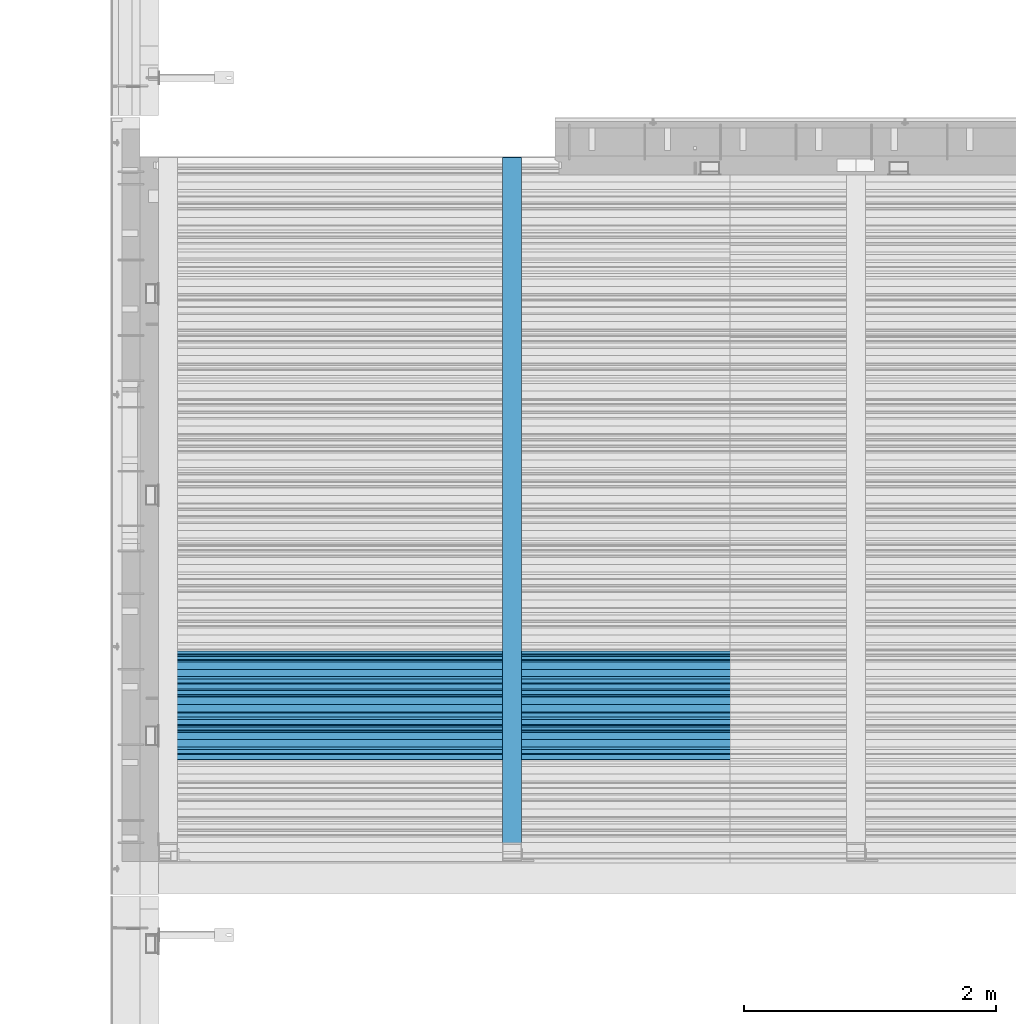
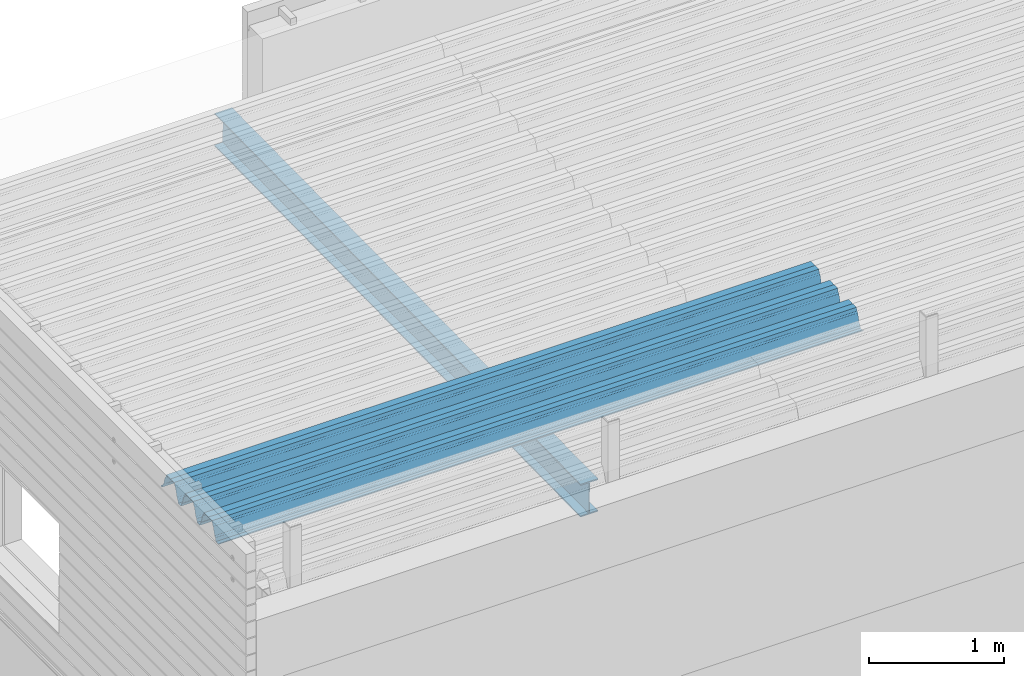
# One storey, part 25 of 153: 2 beams, 2 elements without a shape of their own.
"""IFC2X3 building model written with IfcOpenShell, lengths in millimetres."""

import ifcopenshell
import ifcopenshell.guid

model = None  # the IFC model being written
_history = None  # IfcOwnerHistory: only IFC2X3 demands one
_inside = {}  # id of a spatial element -> (the spatial element, [elements in it])
_under = {}  # id of a project, library or spatial element -> (it, [spatial elements below it])
_declared = {}  # id of a project -> (the project, [libraries it declares])
_typed = {}  # id of a type object -> (the type object, [elements of that type])
_made_of = {}  # id of a material, layer set ... -> (it, [elements and type objects made of it])


def new_model(schema):
    """Start an empty IFC model of exactly this schema.

    Asked for "IFC4X3", IfcOpenShell would pick the latest addendum, in which some entities
    have other attributes; the version numbers below select the first issue.
    IFC2X3 requires an IfcOwnerHistory on every rooted entity: one is made here for all.
    """
    global model, _history
    if schema == "IFC4X3":
        model = ifcopenshell.file(schema_version=(4, 3, 0, 0))
    else:
        model = ifcopenshell.file(schema=schema)
    _inside.clear()
    _under.clear()
    _declared.clear()
    _typed.clear()
    _made_of.clear()
    _history = None
    if model.schema == "IFC2X3":
        org = make("IfcOrganization", Name="unknown")
        user = make(
            "IfcPersonAndOrganization",
            ThePerson=make("IfcPerson", FamilyName="unknown"),
            TheOrganization=org,
        )
        app = make(
            "IfcApplication",
            ApplicationDeveloper=org,
            Version="unknown",
            ApplicationFullName="unknown",
            ApplicationIdentifier="unknown",
        )
        _history = make(
            "IfcOwnerHistory",
            OwningUser=user,
            OwningApplication=app,
            ChangeAction="ADDED",
            CreationDate=0,
        )
    return model


def make(cls, **values):
    """One entity of the class cls with the attributes given. An attribute that is None is left unset."""
    return model.create_entity(
        cls, **{name: value for name, value in values.items() if value is not None}
    )


def rooted(cls, **values):
    """An entity with a GlobalId (a new one), such as an element, a storey or a relation."""
    return make(cls, GlobalId=ifcopenshell.guid.new(), OwnerHistory=_history, **values)


def si_unit(unit_type, name, prefix=None):
    """IfcSIUnit, for example si_unit("LENGTHUNIT", "METRE", prefix="MILLI")."""
    return make("IfcSIUnit", UnitType=unit_type, Prefix=prefix, Name=name)


def assignment(units):
    """IfcUnitAssignment: the units of a project."""
    return None if units is None else make("IfcUnitAssignment", Units=units)


def point(xyz):
    """IfcCartesianPoint."""
    return None if xyz is None else make("IfcCartesianPoint", Coordinates=xyz)


def direction(xyz):
    """IfcDirection."""
    return None if xyz is None else make("IfcDirection", DirectionRatios=xyz)


def frame(location, z_axis=None, x_axis=None):
    """IfcAxis2Placement3D, a coordinate frame: its origin and axes. An axis left out is left unset."""
    return make(
        "IfcAxis2Placement3D",
        Location=point(location),
        Axis=direction(z_axis),
        RefDirection=direction(x_axis),
    )


def origin_with_axes():
    """The frame at (0, 0, 0) with the z axis (0, 0, 1) and the x axis (1, 0, 0) written out."""
    return frame((0.0, 0.0, 0.0), z_axis=(0.0, 0.0, 1.0), x_axis=(1.0, 0.0, 0.0))


def place(relative_to, where):
    """IfcLocalPlacement: puts the frame where relative to a parent placement (None: the world)."""
    return make(
        "IfcLocalPlacement", PlacementRelTo=relative_to, RelativePlacement=where
    )


def context(
    kind, dimensions, precision=None, world=None, true_north=None, identifier=None
):
    """IfcGeometricRepresentationContext, for example the 3D "Model" context."""
    return make(
        "IfcGeometricRepresentationContext",
        ContextIdentifier=identifier,
        ContextType=kind,
        CoordinateSpaceDimension=dimensions,
        Precision=precision,
        WorldCoordinateSystem=world,
        TrueNorth=true_north,
    )


def subcontext(parent, identifier, kind, view, scale=None):
    """IfcGeometricRepresentationSubContext, for example "Body" below "Model"."""
    return make(
        "IfcGeometricRepresentationSubContext",
        ContextIdentifier=identifier,
        ContextType=kind,
        ParentContext=parent,
        TargetScale=scale,
        TargetView=view,
    )


def project(units=None, contexts=None):
    """IfcProject with its units and contexts."""
    return rooted(
        "IfcProject",
        Name="project",
        RepresentationContexts=contexts,
        UnitsInContext=assignment(units),
    )


def spatial(cls, under=None, at=None, **own):
    """A site, building, storey or space (cls), placed at a placement, below another one or the project."""
    s = rooted(cls, ObjectPlacement=at, **own)
    if under is not None:
        _under.setdefault(under.id(), (under, []))[1].append(s)
    return s


def faces_of(points, faces, orient=None, outer=None):
    """IfcFace entities. A face is a list of loops; a loop is a list of indices into points, from 0.

    orient and outer hold one flag for each loop. By default every Orientation is true, the
    first loop of a face is its IfcFaceOuterBound and the others are IfcFaceBound.
    """
    made = []
    for i, loops in enumerate(faces):
        bounds = []
        for j, loop in enumerate(loops):
            is_outer = j == 0 if outer is None else outer[i][j]
            bounds.append(
                make(
                    "IfcFaceOuterBound" if is_outer else "IfcFaceBound",
                    Bound=make("IfcPolyLoop", Polygon=[points[k] for k in loop]),
                    Orientation=True if orient is None else orient[i][j],
                )
            )
        made.append(make("IfcFace", Bounds=bounds))
    return made


def faceted_brep(points, faces, orient=None, outer=None, voids=None):
    """IfcFacetedBrep: a solid bounded by flat faces; with voids (closed shells), ...WithVoids."""
    shared = [point(p) for p in points]
    hull = make("IfcClosedShell", CfsFaces=faces_of(shared, faces, orient, outer))
    if voids is None:
        return make("IfcFacetedBrep", Outer=hull)
    return make(
        "IfcFacetedBrepWithVoids",
        Outer=hull,
        Voids=[
            make(cls, CfsFaces=faces_of(shared, fs, o, b)) for cls, fs, o, b in voids
        ],
    )


def shape(context_of_items, identifier, shape_type, items):
    """IfcShapeRepresentation: the items that make up one representation, for example the "Body"."""
    return make(
        "IfcShapeRepresentation",
        ContextOfItems=context_of_items,
        RepresentationIdentifier=identifier,
        RepresentationType=shape_type,
        Items=items,
    )


def material(Name=None, Category=None):
    """IfcMaterial."""
    return make("IfcMaterial", Name=Name, Category=Category)


def made_of(thing, what):
    """Note that an element or type object is made of a material, layer set ...; save() writes the relation."""
    if what is not None:
        _made_of.setdefault(what.id(), (what, []))[1].append(thing)
    return thing


def type_object(cls, material=None, **own):
    """A type object (cls), such as IfcWallType, which elements share."""
    return made_of(rooted(cls, **own), material)


def element(
    cls,
    number,
    at=None,
    inside=None,
    cuts=None,
    type_object=None,
    material=None,
    context=None,
    identifier="Body",
    shape_type=None,
    held_by="IfcProductDefinitionShape",
    body=None,
    shapes=None,
    **own,
):
    """One element of the class cls, such as IfcWall. Its Tag is "e" and its number.

    at: its placement. inside: the storey or other place that contains it. cuts: it is an
    opening in that element (IfcRelVoidsElement). A single representation is given by context,
    identifier, shape_type and body (its items); several are given by shapes. held_by: the class
    of the entity that holds the representations. save() writes the other relations.
    """
    e = rooted(cls, Tag="e%d" % number, ObjectPlacement=at, **own)
    if body is not None:
        shapes = [shape(context, identifier, shape_type, body)]
    if shapes is not None:
        e.Representation = make(held_by, Representations=shapes)
    if inside is not None:
        _inside.setdefault(inside.id(), (inside, []))[1].append(e)
    if cuts is not None:
        rooted(
            "IfcRelVoidsElement", RelatingBuildingElement=cuts, RelatedOpeningElement=e
        )
    if type_object is not None:
        _typed.setdefault(type_object.id(), (type_object, []))[1].append(e)
    return made_of(e, material)


def aggregate(whole, parts):
    """IfcRelAggregates: a whole, such as a stair, and the parts it consists of."""
    return rooted("IfcRelAggregates", RelatingObject=whole, RelatedObjects=parts)


def save(model, path):
    """Write the relations noted so far, then the file.

    IfcRelAggregates (storeys below a building ...), IfcRelContainedInSpatialStructure (elements
    in a storey), IfcRelDefinesByType, IfcRelAssociatesMaterial and IfcRelDeclares: one each for
    every whole, place, type object, material and project.
    """
    for whole, parts in _under.values():
        aggregate(whole, parts)
    for where, things in _inside.values():
        rooted(
            "IfcRelContainedInSpatialStructure",
            RelatedElements=things,
            RelatingStructure=where,
        )
    for kind, things in _typed.values():
        rooted("IfcRelDefinesByType", RelatedObjects=things, RelatingType=kind)
    for what, things in _made_of.values():
        rooted("IfcRelAssociatesMaterial", RelatedObjects=things, RelatingMaterial=what)
    for by, libraries in _declared.values():
        rooted("IfcRelDeclares", RelatingContext=by, RelatedDefinitions=libraries)
    model.write(path)


model = new_model("IFC2X3")

# Units and contexts
model_context = context("Model", 3, precision=1e-05, world=origin_with_axes())
body_context = subcontext(model_context, "Body", "Model", "MODEL_VIEW")
ifc_project = project(units=[si_unit("LENGTHUNIT", "METRE", prefix="MILLI"), si_unit("AREAUNIT", "SQUARE_METRE"), si_unit("VOLUMEUNIT", "CUBIC_METRE"), si_unit("MASSUNIT", "GRAM", prefix="KILO"), si_unit("TIMEUNIT", "SECOND"), si_unit("PLANEANGLEUNIT", "RADIAN"), si_unit("SOLIDANGLEUNIT", "STERADIAN"), si_unit("THERMODYNAMICTEMPERATUREUNIT", "DEGREE_CELSIUS"), si_unit("LUMINOUSINTENSITYUNIT", "LUMEN")], contexts=[model_context])

# Site, building, storey
site_placement = place(None, origin_with_axes())
site = spatial("IfcSite", under=ifc_project, at=site_placement, CompositionType="ELEMENT")
building_placement = place(site_placement, origin_with_axes())
building = spatial("IfcBuilding", under=site, at=building_placement, CompositionType="ELEMENT")
storey_placement = place(building_placement, origin_with_axes())
storey = spatial("IfcBuildingStorey", under=building, at=storey_placement, Name="8", CompositionType="ELEMENT", Elevation=0.0)

# Assembly, beam
assembly_1_placement = place(storey_placement, origin_with_axes())
assembly_1 = element("IfcElementAssembly", 1, at=assembly_1_placement, inside=storey, Name="Steel Assembly", AssemblyPlace="NOTDEFINED", PredefinedType="RIGID_FRAME")
ifc_material = material(Name="STEEL/S355J2")
beam_type_1 = type_object("IfcBeamType", Name="IPE300", PredefinedType="NOTDEFINED")
beam_1_placement = place(assembly_1_placement, frame((10805.0, 15128.0908589797, 105518.668698055), z_axis=(0.0, -0.0124990270013869, 0.999921884110963), x_axis=(0.0, 0.999921884110963, 0.0124990270013883)))
beam_1 = element("IfcBeam", 2, at=beam_1_placement, type_object=beam_type_1, material=ifc_material, ObjectType="IPE300", context=body_context, shape_type="Brep", body=[
    faceted_brep([(3.63797880709171e-12, 75.0, -149.999999999985), (0.0, 75.0, -139.300000189993), (5440.87494889885, 75.0, -139.300000189993), (5440.87494889886, 75.0, -150.0), (0.0, 3.5499999525, -139.300000189993), (5440.87494889885, 3.5499999525, -139.300000189993), (0.0, 3.5499999525, 139.300000190022), (5440.87494889885, 3.5499999525, 139.300000190022), (0.0, 75.0, 139.300000190022), (5440.87494889885, 75.0, 139.300000190022), (3.63797880709171e-12, 75.0, 150.0), (5440.87494889885, 75.0, 150.0), (3.63797880709171e-12, -75.0, 150.0), (5440.87494889885, -75.0, 150.0), (0.0, -75.0, 139.300000190022), (5440.87494889885, -75.0, 139.300000190022), (0.0, -3.5499999525, 139.300000190022), (5440.87494889885, -3.5499999525, 139.300000190022), (0.0, -3.5499999525, -139.300000189993), (5440.87494889885, -3.5499999525, -139.300000189993), (0.0, -75.0, -139.300000189993), (5440.87494889885, -75.0, -139.300000189993), (3.63797880709171e-12, -75.0, -149.999999999985), (5440.87494889886, -75.0, -150.0)], [[[0, 1, 2, 3]], [[1, 4, 5, 2]], [[4, 6, 7, 5]], [[6, 8, 9, 7]], [[8, 10, 11, 9]], [[10, 12, 13, 11]], [[12, 14, 15, 13]], [[14, 16, 17, 15]], [[16, 18, 19, 17]], [[18, 20, 21, 19]], [[20, 22, 23, 21]], [[22, 0, 3, 23]], [[5, 7, 9, 11, 13, 15, 17, 19, 21, 23, 3, 2]], [[22, 20, 18, 16, 14, 12, 10, 8, 6, 4, 1, 0]]]),
])
aggregate(assembly_1, [beam_1])

assembly_2_placement = place(storey_placement, origin_with_axes())
assembly_2 = element("IfcElementAssembly", 3, at=assembly_2_placement, inside=storey, Name="Steel Assembly", AssemblyPlace="NOTDEFINED", PredefinedType="RIGID_FRAME")
beam_type_2 = type_object("IfcBeamType", Name="W", PredefinedType="NOTDEFINED")
beam_2_placement = place(assembly_2_placement, frame((13534.9999999929, 16215.1442180382, 105760.274680782), z_axis=(0.0, -0.0124990270013869, 0.999921884110963), x_axis=(-1.0, 3.00000001838171e-08, 0.0)))
beam_2 = element("IfcBeam", 4, at=beam_2_placement, type_object=beam_type_2, material=ifc_material, ObjectType="W", context=body_context, shape_type="Brep", body=[
    faceted_brep([(0.0, -412.839996337891, -77.0100021362159), (0.0, -409.160003662109, -77.0100021362014), (5530.0, -409.160003662109, -77.0100021362014), (5530.0, -412.839996337891, -77.0100021362159), (0.0, -408.070007324222, -73.4800033569045), (5530.0, -408.070007324222, -73.4800033569045), (0.0, -400.339996337894, -48.0600013732619), (5530.0, -400.339996337894, -48.0600013732619), (0.0, -399.459991455082, -46.5600013732619), (5530.0, -399.459991455082, -46.5600013732619), (0.0, -390.329986572269, -36.5499992370314), (5530.0, -390.329986572269, -36.5499992370314), (0.0, -389.19000244141, -34.6300010680861), (5530.0, -389.19000244141, -34.6300010680861), (0.0, -367.820007324222, 35.3400001526024), (5530.0, -367.820007324222, 35.3400001526024), (0.0, -366.989990234379, 36.8499984741502), (5530.0, -366.989990234379, 36.8499984741502), (0.0, -357.809997558597, 46.8600006103807), (5530.0, -357.809997558597, 46.8600006103807), (0.0, -356.720001220707, 48.7700004577782), (5530.0, -356.720001220707, 48.7700004577782), (0.0, -349.309997558594, 73.1500015258935), (5530.0, -349.309997558594, 73.1500015258935), (0.0, -347.850006103516, 75.2300033569481), (5530.0, -347.850006103516, 75.2300033569481), (0.0, -345.470001220707, 76.010002136245), (5530.0, -345.470001220707, 76.010002136245), (0.0, -305.480010986332, 76.010002136245), (5530.0, -305.480010986332, 76.010002136245), (0.0, -304.279998779301, 75.8000030517578), (5530.0, -304.279998779301, 75.8000030517578), (0.0, -291.679992675785, 71.6999969482567), (5530.0, -291.679992675785, 71.6999969482567), (0.0, -290.179992675789, 71.2300033569481), (5530.0, -290.179992675789, 71.2300033569481), (0.0, -288.720001220707, 71.6999969482567), (5530.0, -288.720001220707, 71.6999969482567), (0.0, -276.119995117191, 75.8000030517869), (5530.0, -276.119995117191, 75.8000030517869), (0.0, -274.929992675785, 76.010002136245), (5530.0, -274.929992675785, 76.010002136245), (0.0, -234.94000244141, 76.010002136245), (5530.0, -234.94000244141, 76.010002136245), (0.0, -232.550003051758, 75.2300033569627), (5530.0, -232.550003051758, 75.2300033569627), (0.0, -231.100006103519, 73.1500015258935), (5530.0, -231.100006103519, 73.1500015258935), (0.0, -223.679992675785, 48.7700004577782), (5530.0, -223.679992675785, 48.7700004577782), (0.0, -222.589996337894, 46.8600006103661), (5530.0, -222.589996337894, 46.8600006103661), (0.0, -213.410003662113, 36.8499984741502), (5530.0, -213.410003662113, 36.8499984741502), (0.0, -212.529998779301, 35.3400001526024), (5530.0, -212.529998779301, 35.3400001526024), (0.0, -191.160003662109, -34.6300010681007), (5530.0, -191.160003662109, -34.6300010681007), (0.0, -190.070007324222, -36.5499992370605), (5530.0, -190.070007324222, -36.5499992370605), (0.0, -180.940002441406, -46.560001373291), (5530.0, -180.940002441406, -46.560001373291), (0.0, -180.059997558597, -48.0600013732619), (5530.0, -180.059997558597, -48.0600013732619), (0.0, -172.330001831055, -73.480003356919), (5530.0, -172.330001831055, -73.480003356919), (0.0, -171.240005493168, -77.0100021362159), (5530.0, -171.240005493168, -77.0100021362159), (0.0, -129.330001831062, -77.0100021362014), (5530.0, -129.330001831062, -77.0100021362014), (0.0, -128.300003051761, -73.480003356919), (5530.0, -128.300003051761, -73.480003356919), (0.0, -120.51999664307, -48.0600013732765), (5530.0, -120.51999664307, -48.0600013732765), (0.0, -119.629997253418, -46.5600013732765), (5530.0, -119.629997253418, -46.5600013732765), (0.0, -110.500000000004, -36.5499992370314), (5530.0, -110.500000000004, -36.5499992370314), (0.0, -109.419998168949, -34.6300010680861), (5530.0, -109.419998168949, -34.6300010680861), (0.0, -88.0500030517615, 35.3400001526024), (5530.0, -88.0500030517615, 35.3400001526024), (0.0, -87.160003662113, 36.8499984741356), (5530.0, -87.160003662113, 36.8499984741356), (0.0, -78.0400009155273, 46.8600006103807), (5530.0, -78.0400009155273, 46.8600006103807), (0.0, -76.8899993896557, 48.7700004577782), (5530.0, -76.8899993896557, 48.7700004577782), (0.0, -69.4800033569336, 73.1500015258935), (5530.0, -69.4800033569336, 73.1500015258935), (0.0, -68.0299987793042, 75.2300033569336), (5530.0, -68.0299987793042, 75.2300033569336), (0.0, -65.6399993896521, 76.010002136245), (5530.0, -65.6399993896521, 76.010002136245), (0.0, -25.6499996185375, 76.0100021362596), (5530.0, -25.6499996185375, 76.0100021362596), (0.0, -24.5100002288891, 75.8000030517724), (5530.0, -24.5100002288891, 75.8000030517724), (0.0, -11.8500003814697, 71.6999969482567), (5530.0, -11.8500003814697, 71.6999969482567), (0.0, -10.3999996185339, 71.2300033569481), (5530.0, -10.3999996185339, 71.2300033569481), (0.0, -8.89999961853391, 71.6999969482567), (5530.0, -8.89999961853391, 71.6999969482567), (0.0, 3.71000003814333, 75.8000030517724), (5530.0, 3.71000003814333, 75.8000030517724), (0.0, 4.90000009536379, 76.0100021362596), (5530.0, 4.90000009536379, 76.0100021362596), (0.0, 44.8899993896484, 76.010002136245), (5530.0, 44.8899993896484, 76.010002136245), (0.0, 47.2799987792932, 75.2300033569481), (5530.0, 47.2799987792932, 75.2300033569481), (0.0, 48.6800003051721, 73.1500015258935), (5530.0, 48.6800003051721, 73.1500015258935), (0.0, 56.1500015258753, 48.7700004577782), (5530.0, 56.1500015258753, 48.7700004577782), (0.0, 57.2400016784632, 46.8600006103807), (5530.0, 57.2400016784632, 46.8600006103807), (0.0, 66.3700027465784, 36.8499984741211), (5530.0, 66.3700027465784, 36.8499984741211), (0.0, 67.2499999999964, 35.3400001526024), (5530.0, 67.2499999999964, 35.3400001526024), (0.0, 88.6200027465748, -34.6300010681007), (5530.0, 88.6200027465748, -34.6300010681007), (0.0, 89.709999084469, -36.549999237046), (5530.0, 89.709999084469, -36.549999237046), (0.0, 98.8899993896412, -46.5600013732765), (5530.0, 98.8899993896412, -46.5600013732765), (0.0, 99.7699966430628, -48.0600013732765), (5530.0, 99.7699966430628, -48.0600013732765), (0.0, 107.499999999996, -73.4800033569336), (5530.0, 107.499999999996, -73.4800033569336), (0.0, 108.589996337887, -77.0100021362014), (5530.0, 108.589996337887, -77.0100021362014), (0.0, 112.269996643063, -77.0100021362159), (5530.0, 112.269996643063, -77.0100021362159), (0.0, 146.759994506836, -77.0100021362159), (5530.0, 146.759994506836, -77.0100021362159), (0.0, 150.440002441403, -77.0100021362159), (5530.0, 150.440002441403, -77.0100021362159), (0.0, 151.529998779297, -73.480003356919), (5530.0, 151.529998779297, -73.480003356919), (0.0, 159.30999755859, -48.0600013732765), (5530.0, 159.30999755859, -48.0600013732765), (0.0, 160.190002441406, -46.5600013732619), (5530.0, 160.190002441406, -46.5600013732619), (0.0, 169.320007324215, -36.549999237046), (5530.0, 169.320007324215, -36.549999237046), (0.0, 170.410003662106, -34.6300010680861), (5530.0, 170.410003662106, -34.6300010680861), (0.0, 191.779998779293, 35.3400001526024), (5530.0, 191.779998779293, 35.3400001526024), (0.0, 192.660003662109, 36.8499984741502), (5530.0, 192.660003662109, 36.8499984741502), (0.0, 201.789993286129, 46.8600006103661), (5530.0, 201.789993286129, 46.8600006103661), (0.0, 202.880004882809, 48.7700004577637), (5530.0, 202.880004882809, 48.7700004577637), (0.0, 210.350006103512, 73.150001525908), (5530.0, 210.350006103512, 73.150001525908), (0.0, 211.800003051754, 75.2300033569481), (5530.0, 211.800003051754, 75.2300033569481), (0.0, 214.190002441406, 76.010002136245), (5530.0, 214.190002441406, 76.010002136245), (0.0, 254.179992675778, 76.010002136245), (5530.0, 254.179992675778, 76.010002136245), (0.0, 255.320007324215, 75.8000030517869), (5530.0, 255.320007324215, 75.8000030517869), (0.0, 267.980010986324, 71.6999969482713), (5530.0, 267.980010986324, 71.6999969482713), (0.0, 269.429992675778, 71.2300033569481), (5530.0, 269.429992675778, 71.2300033569481), (0.0, 270.880004882809, 71.6999969482567), (5530.0, 270.880004882809, 71.6999969482567), (0.0, 283.540008544918, 75.8000030517869), (5530.0, 283.540008544918, 75.8000030517869), (0.0, 284.679992675778, 76.010002136245), (5530.0, 284.679992675778, 76.010002136245), (0.0, 324.670013427731, 76.010002136245), (5530.0, 324.670013427731, 76.010002136245), (0.0, 327.049987792969, 75.2300033569627), (5530.0, 327.049987792969, 75.2300033569627), (0.0, 328.510009765625, 73.1500015258789), (5530.0, 328.510009765625, 73.1500015258789), (0.0, 335.980010986324, 48.7700004577782), (5530.0, 335.980010986324, 48.7700004577782), (0.0, 337.05999755859, 46.8600006103661), (5530.0, 337.05999755859, 46.8600006103661), (0.0, 346.190002441399, 36.8499984741356), (5530.0, 346.190002441399, 36.8499984741356), (0.0, 347.079986572266, 35.3400001526024), (5530.0, 347.079986572266, 35.3400001526024), (0.0, 368.450012207028, -34.6300010680861), (5530.0, 368.450012207028, -34.6300010680861), (0.0, 369.529998779293, -36.5499992370314), (5530.0, 369.529998779293, -36.5499992370314), (0.0, 378.660003662106, -46.5600013732619), (5530.0, 378.660003662106, -46.5600013732619), (0.0, 379.540008544918, -48.0600013732619), (5530.0, 379.540008544918, -48.0600013732619), (0.0, 387.329986572262, -73.480003356919), (5530.0, 387.329986572262, -73.480003356919), (0.0, 388.410003662109, -77.0100021362159), (5530.0, 388.410003662109, -77.0100021362159), (0.0, 392.100006103512, -77.0100021362159), (5530.0, 392.100006103512, -77.0100021362159), (0.0, 426.589996337887, -77.0100021362159), (5530.0, 426.589996337887, -77.0100021362159), (0.0, 430.269989013668, -77.0100021362159), (5530.0, 430.269989013668, -77.0100021362159), (0.0, 431.359985351559, -73.4800033569045), (5530.0, 431.359985351559, -73.4800033569045), (0.0, 433.179992675778, -67.5699996948097), (5530.0, 433.179992675778, -67.5699996948097), (0.0, 432.220001220699, -67.2699966430373), (5530.0, 432.220001220699, -67.2699966430373), (0.0, 430.410003662106, -73.1800003051612), (5530.0, 430.410003662106, -73.1800003051612), (0.0, 429.529998779293, -76.0100021362159), (5530.0, 429.529998779293, -76.0100021362159), (0.0, 426.589996337891, -76.0100021362159), (5530.0, 426.589996337891, -76.0100021362159), (0.0, 392.100006103512, -76.0100021362159), (5530.0, 392.100006103512, -76.0100021362159), (0.0, 389.149993896481, -76.0100021362014), (5530.0, 389.149993896481, -76.0100021362014), (0.0, 388.279998779293, -73.1800003051467), (5530.0, 388.279998779293, -73.1800003051467), (0.0, 380.470001220699, -47.659999847383), (5530.0, 380.470001220699, -47.659999847383), (0.0, 379.470001220699, -45.9599990844436), (5530.0, 379.470001220699, -45.9599990844436), (0.0, 370.350006103512, -35.9599990844581), (5530.0, 370.350006103512, -35.9599990844581), (0.0, 369.369995117184, -34.2299995422218), (5530.0, 369.369995117184, -34.2299995422218), (0.0, 347.999999999996, 35.7500000000146), (5530.0, 347.999999999996, 35.7500000000146), (0.0, 346.999999999996, 37.4399986267235), (5530.0, 346.999999999996, 37.4399986267235), (0.0, 337.880004882809, 47.450000762954), (5530.0, 337.880004882809, 47.450000762954), (0.0, 336.899993896481, 49.1699981689453), (5530.0, 336.899993896481, 49.1699981689453), (0.0, 329.420013427731, 73.5999984741356), (5530.0, 329.420013427731, 73.5999984741356), (0.0, 327.679992675781, 76.0699996948533), (5530.0, 327.679992675781, 76.0699996948533), (0.0, 324.829986572262, 77.010002136245), (5530.0, 324.829986572262, 77.010002136245), (0.0, 284.589996337887, 77.010002136245), (5530.0, 284.589996337887, 77.010002136245), (0.0, 283.290008544922, 76.769996643081), (5530.0, 283.290008544922, 76.769996643081), (0.0, 270.570007324215, 72.6500015258935), (5530.0, 270.570007324215, 72.6500015258935), (0.0, 269.429992675781, 72.2799987793114), (5530.0, 269.429992675781, 72.2799987793114), (0.0, 268.279998779293, 72.650001525908), (5530.0, 268.279998779293, 72.650001525908), (0.0, 255.570007324219, 76.769996643081), (5530.0, 255.570007324219, 76.769996643081), (0.0, 254.270004272461, 77.0100021362596), (5530.0, 254.270004272461, 77.0100021362596), (0.0, 214.029998779293, 77.0100021362596), (5530.0, 214.029998779293, 77.0100021362596), (0.0, 211.179992675781, 76.0699996948388), (5530.0, 211.179992675781, 76.0699996948388), (0.0, 209.440002441403, 73.5999984741356), (5530.0, 209.440002441403, 73.5999984741356), (0.0, 201.960006713864, 49.1699981689599), (5530.0, 201.960006713864, 49.1699981689599), (0.0, 200.979995727532, 47.450000762954), (5530.0, 200.979995727532, 47.450000762954), (0.0, 191.850006103508, 37.4399986267235), (5530.0, 191.850006103508, 37.4399986267235), (0.0, 190.860000610352, 35.7500000000146), (5530.0, 190.860000610352, 35.7500000000146), (0.0, 169.49000549316, -34.2299995422218), (5530.0, 169.49000549316, -34.2299995422218), (0.0, 168.509994506832, -35.9599990844581), (5530.0, 168.509994506832, -35.9599990844581), (0.0, 159.380004882805, -45.9599990844436), (5530.0, 159.380004882805, -45.9599990844436), (0.0, 158.389999389645, -47.6599998473976), (5530.0, 158.389999389645, -47.6599998473976), (0.0, 150.580001831051, -73.1800003051612), (5530.0, 150.580001831051, -73.1800003051612), (0.0, 149.710006713864, -76.0100021362159), (5530.0, 149.710006713864, -76.0100021362159), (0.0, 146.759994506836, -76.0100021362159), (5530.0, 146.759994506836, -76.0100021362159), (0.0, 112.269996643063, -76.0100021362159), (5530.0, 112.269996643063, -76.0100021362159), (0.0, 109.319999694821, -76.0100021362159), (5530.0, 109.319999694821, -76.0100021362159), (0.0, 108.449996948239, -73.1900024413917), (5530.0, 108.449996948239, -73.1900024413917), (0.0, 100.690002441406, -47.659999847383), (5530.0, 100.690002441406, -47.659999847383), (0.0, 99.6999969482386, -45.9599990844581), (5530.0, 99.6999969482386, -45.9599990844581), (0.0, 90.5199966430664, -35.9599990844581), (5530.0, 90.5199966430664, -35.9599990844581), (0.0, 89.5400009155273, -34.2299995422218), (5530.0, 89.5400009155273, -34.2299995422218), (0.0, 68.1699981689417, 35.7500000000146), (5530.0, 68.1699981689417, 35.7500000000146), (0.0, 67.1699981689417, 37.4399986267235), (5530.0, 67.1699981689417, 37.4399986267235), (0.0, 58.0499992370569, 47.4500007629686), (5530.0, 58.0499992370569, 47.4500007629686), (0.0, 57.0699996948206, 49.1699981689599), (5530.0, 57.0699996948206, 49.1699981689599), (0.0, 49.5900001525843, 73.5899963379052), (5530.0, 49.5900001525843, 73.5899963379052), (0.0, 47.9099998474085, 76.0699996948388), (5530.0, 47.9099998474085, 76.0699996948388), (0.0, 45.0499992370569, 77.010002136245), (5530.0, 45.0499992370569, 77.010002136245), (0.0, 4.82000017165774, 77.010002136245), (5530.0, 4.82000017165774, 77.010002136245), (0.0, 3.47000002860659, 76.7699966430955), (5530.0, 3.47000002860659, 76.7699966430955), (0.0, -9.19999980926514, 72.6500015258935), (5530.0, -9.19999980926514, 72.6500015258935), (0.0, -10.3900003433264, 72.2799987792969), (5530.0, -10.3900003433264, 72.2799987792969), (0.0, -11.5399999618567, 72.6500015258935), (5530.0, -11.5399999618567, 72.6500015258935), (0.0, -24.2600002288855, 76.769996643081), (5530.0, -24.2600002288855, 76.769996643081), (0.0, -25.559999465946, 77.0100021362596), (5530.0, -25.559999465946, 77.0100021362596), (0.0, -65.8000030517615, 77.0100021362596), (5530.0, -65.8000030517615, 77.0100021362596), (0.0, -68.6500015258862, 76.0699996948533), (5530.0, -68.6500015258862, 76.0699996948533), (0.0, -70.3899993896521, 73.5999984741356), (5530.0, -70.3899993896521, 73.5999984741356), (0.0, -77.8199996948242, 49.1800003051903), (5530.0, -77.8199996948242, 49.1800003051903), (0.0, -78.8399963378943, 47.450000762954), (5530.0, -78.8399963378943, 47.450000762954), (0.0, -87.9700012207031, 37.4399986267235), (5530.0, -87.9700012207031, 37.4399986267235), (0.0, -88.9700012207068, 35.7500000000146), (5530.0, -88.9700012207068, 35.7500000000146), (0.0, -110.339996337894, -34.2299995422218), (5530.0, -110.339996337894, -34.2299995422218), (0.0, -111.319999694828, -35.9599990844581), (5530.0, -111.319999694828, -35.9599990844581), (0.0, -120.440002441406, -45.9599990844436), (5530.0, -120.440002441406, -45.9599990844436), (0.0, -121.44000244141, -47.6599998473976), (5530.0, -121.44000244141, -47.6599998473976), (0.0, -129.250000000004, -73.1900024413771), (5530.0, -129.250000000004, -73.1900024413771), (0.0, -130.080001831062, -76.0100021362159), (5530.0, -130.080001831062, -76.0100021362159), (0.0, -170.5, -76.0100021362014), (5530.0, -170.5, -76.0100021362014), (0.0, -171.380004882816, -73.1900024413917), (5530.0, -171.380004882816, -73.1900024413917), (0.0, -179.139999389652, -47.6599998473976), (5530.0, -179.139999389652, -47.6599998473976), (0.0, -180.130004882816, -45.9599990844581), (5530.0, -180.130004882816, -45.9599990844581), (0.0, -189.259994506836, -35.9599990844581), (5530.0, -189.259994506836, -35.9599990844581), (0.0, -190.240005493168, -34.2299995422218), (5530.0, -190.240005493168, -34.2299995422218), (0.0, -211.610000610355, 35.7500000000146), (5530.0, -211.610000610355, 35.7500000000146), (0.0, -212.600006103519, 37.4399986267381), (5530.0, -212.600006103519, 37.4399986267381), (0.0, -221.779998779301, 47.450000762954), (5530.0, -221.779998779301, 47.450000762954), (0.0, -222.75999450684, 49.1699981689599), (5530.0, -222.75999450684, 49.1699981689599), (0.0, -230.190002441406, 73.5999984741356), (5530.0, -230.190002441406, 73.5999984741356), (0.0, -231.919998168945, 76.0699996948388), (5530.0, -231.919998168945, 76.0699996948388), (0.0, -234.779998779301, 77.010002136245), (5530.0, -234.779998779301, 77.010002136245), (0.0, -275.010009765629, 77.010002136245), (5530.0, -275.010009765629, 77.010002136245), (0.0, -276.359985351563, 76.769996643081), (5530.0, -276.359985351563, 76.769996643081), (0.0, -289.029998779297, 72.6500015258789), (5530.0, -289.029998779297, 72.6500015258789), (0.0, -290.179992675785, 72.2799987793114), (5530.0, -290.179992675785, 72.2799987793114), (0.0, -291.380004882816, 72.650001525908), (5530.0, -291.380004882816, 72.650001525908), (0.0, -304.040008544926, 76.769996643081), (5530.0, -304.040008544926, 76.769996643081), (0.0, -305.390014648441, 77.010002136245), (5530.0, -305.390014648441, 77.010002136245), (0.0, -345.63000488282, 77.0100021362596), (5530.0, -345.63000488282, 77.0100021362596), (0.0, -348.480010986332, 76.0699996948388), (5530.0, -348.480010986332, 76.0699996948388), (0.0, -350.220001220707, 73.5999984741356), (5530.0, -350.220001220707, 73.5999984741356), (0.0, -357.649993896492, 49.1699981689599), (5530.0, -357.649993896492, 49.1699981689599), (0.0, -358.63000488282, 47.450000762954), (5530.0, -358.63000488282, 47.450000762954), (0.0, -367.809997558594, 37.4300003051903), (5530.0, -367.809997558594, 37.4300003051903), (0.0, -368.750000000004, 35.7299995422654), (5530.0, -368.750000000004, 35.7299995422654), (0.0, -390.109985351566, -34.2200012207031), (5530.0, -390.109985351566, -34.2200012207031), (0.0, -391.140014648441, -35.9500007629249), (5530.0, -391.140014648441, -35.9500007629249), (0.0, -400.269989013676, -45.9599990844436), (5530.0, -400.269989013676, -45.9599990844436), (0.0, -401.269989013672, -47.6599998473976), (5530.0, -401.269989013672, -47.6599998473976), (0.0, -409.029998779297, -73.1900024413917), (5530.0, -409.029998779297, -73.1900024413917), (0.0, -409.899993896488, -76.0100021362159), (5530.0, -409.899993896488, -76.0100021362159), (0.0, -412.839996337891, -76.0100021362159), (5530.0, -412.839996337891, -76.0100021362159), (0.0, -433.179992675785, -76.0100021362159), (5530.0, -433.179992675785, -76.0100021362159), (0.0, -433.179992675785, -77.0100021362159), (5530.0, -433.179992675785, -77.0100021362159)], [[[0, 1, 2, 3]], [[1, 4, 5, 2]], [[4, 6, 7, 5]], [[6, 8, 9, 7]], [[8, 10, 11, 9]], [[10, 12, 13, 11]], [[12, 14, 15, 13]], [[14, 16, 17, 15]], [[16, 18, 19, 17]], [[18, 20, 21, 19]], [[20, 22, 23, 21]], [[22, 24, 25, 23]], [[24, 26, 27, 25]], [[26, 28, 29, 27]], [[28, 30, 31, 29]], [[30, 32, 33, 31]], [[32, 34, 35, 33]], [[34, 36, 37, 35]], [[36, 38, 39, 37]], [[38, 40, 41, 39]], [[40, 42, 43, 41]], [[42, 44, 45, 43]], [[44, 46, 47, 45]], [[46, 48, 49, 47]], [[48, 50, 51, 49]], [[50, 52, 53, 51]], [[52, 54, 55, 53]], [[54, 56, 57, 55]], [[56, 58, 59, 57]], [[58, 60, 61, 59]], [[60, 62, 63, 61]], [[62, 64, 65, 63]], [[64, 66, 67, 65]], [[66, 68, 69, 67]], [[68, 70, 71, 69]], [[70, 72, 73, 71]], [[72, 74, 75, 73]], [[74, 76, 77, 75]], [[76, 78, 79, 77]], [[78, 80, 81, 79]], [[80, 82, 83, 81]], [[82, 84, 85, 83]], [[84, 86, 87, 85]], [[86, 88, 89, 87]], [[88, 90, 91, 89]], [[90, 92, 93, 91]], [[92, 94, 95, 93]], [[94, 96, 97, 95]], [[96, 98, 99, 97]], [[98, 100, 101, 99]], [[100, 102, 103, 101]], [[102, 104, 105, 103]], [[104, 106, 107, 105]], [[106, 108, 109, 107]], [[108, 110, 111, 109]], [[110, 112, 113, 111]], [[112, 114, 115, 113]], [[114, 116, 117, 115]], [[116, 118, 119, 117]], [[118, 120, 121, 119]], [[120, 122, 123, 121]], [[122, 124, 125, 123]], [[124, 126, 127, 125]], [[126, 128, 129, 127]], [[128, 130, 131, 129]], [[130, 132, 133, 131]], [[132, 134, 135, 133]], [[134, 136, 137, 135]], [[136, 138, 139, 137]], [[138, 140, 141, 139]], [[140, 142, 143, 141]], [[142, 144, 145, 143]], [[144, 146, 147, 145]], [[146, 148, 149, 147]], [[148, 150, 151, 149]], [[150, 152, 153, 151]], [[152, 154, 155, 153]], [[154, 156, 157, 155]], [[156, 158, 159, 157]], [[158, 160, 161, 159]], [[160, 162, 163, 161]], [[162, 164, 165, 163]], [[164, 166, 167, 165]], [[166, 168, 169, 167]], [[168, 170, 171, 169]], [[170, 172, 173, 171]], [[172, 174, 175, 173]], [[174, 176, 177, 175]], [[176, 178, 179, 177]], [[178, 180, 181, 179]], [[180, 182, 183, 181]], [[182, 184, 185, 183]], [[184, 186, 187, 185]], [[186, 188, 189, 187]], [[188, 190, 191, 189]], [[190, 192, 193, 191]], [[192, 194, 195, 193]], [[194, 196, 197, 195]], [[196, 198, 199, 197]], [[198, 200, 201, 199]], [[200, 202, 203, 201]], [[202, 204, 205, 203]], [[204, 206, 207, 205]], [[206, 208, 209, 207]], [[208, 210, 211, 209]], [[210, 212, 213, 211]], [[212, 214, 215, 213]], [[214, 216, 217, 215]], [[216, 218, 219, 217]], [[218, 220, 221, 219]], [[220, 222, 223, 221]], [[222, 224, 225, 223]], [[224, 226, 227, 225]], [[226, 228, 229, 227]], [[228, 230, 231, 229]], [[230, 232, 233, 231]], [[232, 234, 235, 233]], [[234, 236, 237, 235]], [[236, 238, 239, 237]], [[238, 240, 241, 239]], [[240, 242, 243, 241]], [[242, 244, 245, 243]], [[244, 246, 247, 245]], [[246, 248, 249, 247]], [[248, 250, 251, 249]], [[250, 252, 253, 251]], [[252, 254, 255, 253]], [[254, 256, 257, 255]], [[256, 258, 259, 257]], [[258, 260, 261, 259]], [[260, 262, 263, 261]], [[262, 264, 265, 263]], [[264, 266, 267, 265]], [[266, 268, 269, 267]], [[268, 270, 271, 269]], [[270, 272, 273, 271]], [[272, 274, 275, 273]], [[274, 276, 277, 275]], [[276, 278, 279, 277]], [[278, 280, 281, 279]], [[280, 282, 283, 281]], [[282, 284, 285, 283]], [[284, 286, 287, 285]], [[286, 288, 289, 287]], [[288, 290, 291, 289]], [[290, 292, 293, 291]], [[292, 294, 295, 293]], [[294, 296, 297, 295]], [[296, 298, 299, 297]], [[298, 300, 301, 299]], [[300, 302, 303, 301]], [[302, 304, 305, 303]], [[304, 306, 307, 305]], [[306, 308, 309, 307]], [[308, 310, 311, 309]], [[310, 312, 313, 311]], [[312, 314, 315, 313]], [[314, 316, 317, 315]], [[316, 318, 319, 317]], [[318, 320, 321, 319]], [[320, 322, 323, 321]], [[322, 324, 325, 323]], [[324, 326, 327, 325]], [[326, 328, 329, 327]], [[328, 330, 331, 329]], [[330, 332, 333, 331]], [[332, 334, 335, 333]], [[334, 336, 337, 335]], [[336, 338, 339, 337]], [[338, 340, 341, 339]], [[340, 342, 343, 341]], [[342, 344, 345, 343]], [[344, 346, 347, 345]], [[346, 348, 349, 347]], [[348, 350, 351, 349]], [[350, 352, 353, 351]], [[352, 354, 355, 353]], [[354, 356, 357, 355]], [[356, 358, 359, 357]], [[358, 360, 361, 359]], [[360, 362, 363, 361]], [[362, 364, 365, 363]], [[364, 366, 367, 365]], [[366, 368, 369, 367]], [[368, 370, 371, 369]], [[370, 372, 373, 371]], [[372, 374, 375, 373]], [[374, 376, 377, 375]], [[376, 378, 379, 377]], [[378, 380, 381, 379]], [[380, 382, 383, 381]], [[382, 384, 385, 383]], [[384, 386, 387, 385]], [[386, 388, 389, 387]], [[388, 390, 391, 389]], [[390, 392, 393, 391]], [[392, 394, 395, 393]], [[394, 396, 397, 395]], [[396, 398, 399, 397]], [[398, 400, 401, 399]], [[400, 402, 403, 401]], [[402, 404, 405, 403]], [[404, 406, 407, 405]], [[406, 408, 409, 407]], [[408, 410, 411, 409]], [[410, 412, 413, 411]], [[412, 414, 415, 413]], [[414, 416, 417, 415]], [[416, 418, 419, 417]], [[418, 420, 421, 419]], [[420, 422, 423, 421]], [[422, 424, 425, 423]], [[424, 426, 427, 425]], [[426, 428, 429, 427]], [[428, 430, 431, 429]], [[430, 0, 3, 431]], [[5, 7, 9, 11, 13, 15, 17, 19, 21, 23, 25, 27, 29, 31, 33, 35, 37, 39, 41, 43, 45, 47, 49, 51, 53, 55, 57, 59, 61, 63, 65, 67, 69, 71, 73, 75, 77, 79, 81, 83, 85, 87, 89, 91, 93, 95, 97, 99, 101, 103, 105, 107, 109, 111, 113, 115, 117, 119, 121, 123, 125, 127, 129, 131, 133, 135, 137, 139, 141, 143, 145, 147, 149, 151, 153, 155, 157, 159, 161, 163, 165, 167, 169, 171, 173, 175, 177, 179, 181, 183, 185, 187, 189, 191, 193, 195, 197, 199, 201, 203, 205, 207, 209, 211, 213, 215, 217, 219, 221, 223, 225, 227, 229, 231, 233, 235, 237, 239, 241, 243, 245, 247, 249, 251, 253, 255, 257, 259, 261, 263, 265, 267, 269, 271, 273, 275, 277, 279, 281, 283, 285, 287, 289, 291, 293, 295, 297, 299, 301, 303, 305, 307, 309, 311, 313, 315, 317, 319, 321, 323, 325, 327, 329, 331, 333, 335, 337, 339, 341, 343, 345, 347, 349, 351, 353, 355, 357, 359, 361, 363, 365, 367, 369, 371, 373, 375, 377, 379, 381, 383, 385, 387, 389, 391, 393, 395, 397, 399, 401, 403, 405, 407, 409, 411, 413, 415, 417, 419, 421, 423, 425, 427, 429, 431, 3, 2]], [[430, 428, 426, 424, 422, 420, 418, 416, 414, 412, 410, 408, 406, 404, 402, 400, 398, 396, 394, 392, 390, 388, 386, 384, 382, 380, 378, 376, 374, 372, 370, 368, 366, 364, 362, 360, 358, 356, 354, 352, 350, 348, 346, 344, 342, 340, 338, 336, 334, 332, 330, 328, 326, 324, 322, 320, 318, 316, 314, 312, 310, 308, 306, 304, 302, 300, 298, 296, 294, 292, 290, 288, 286, 284, 282, 280, 278, 276, 274, 272, 270, 268, 266, 264, 262, 260, 258, 256, 254, 252, 250, 248, 246, 244, 242, 240, 238, 236, 234, 232, 230, 228, 226, 224, 222, 220, 218, 216, 214, 212, 210, 208, 206, 204, 202, 200, 198, 196, 194, 192, 190, 188, 186, 184, 182, 180, 178, 176, 174, 172, 170, 168, 166, 164, 162, 160, 158, 156, 154, 152, 150, 148, 146, 144, 142, 140, 138, 136, 134, 132, 130, 128, 126, 124, 122, 120, 118, 116, 114, 112, 110, 108, 106, 104, 102, 100, 98, 96, 94, 92, 90, 88, 86, 84, 82, 80, 78, 76, 74, 72, 70, 68, 66, 64, 62, 60, 58, 56, 54, 52, 50, 48, 46, 44, 42, 40, 38, 36, 34, 32, 30, 28, 26, 24, 22, 20, 18, 16, 14, 12, 10, 8, 6, 4, 1, 0]]]),
])
aggregate(assembly_2, [beam_2])

save(model, "model.ifc")
